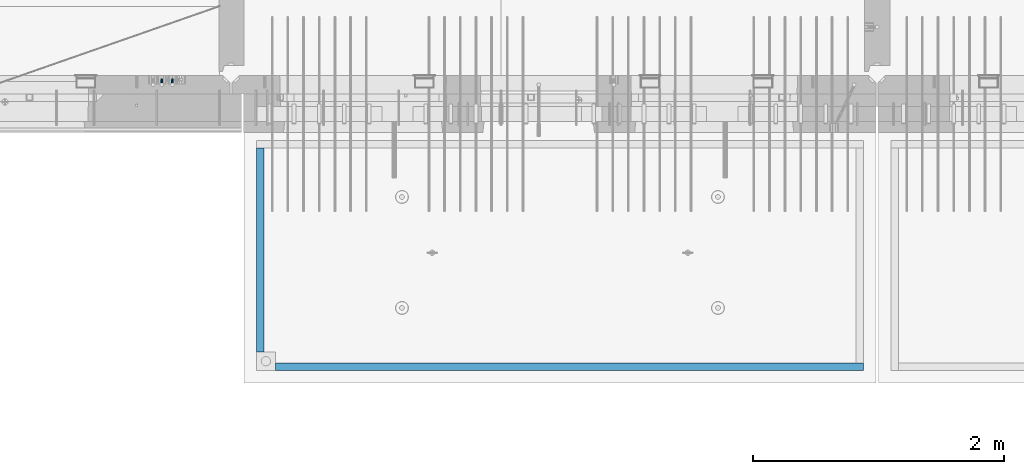
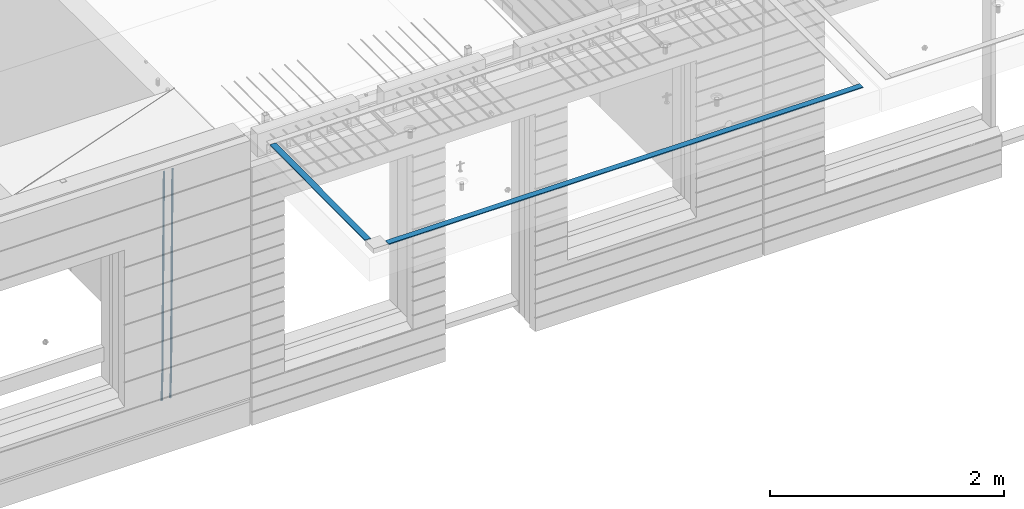
# One storey, part 95 of 350: 4 beams, 2 elements without a shape of their own.
"""IFC2X3 building model written with IfcOpenShell, lengths in millimetres."""

from ifc_helpers import new_model, si_unit, frame, origin_with_axes, place, context, subcontext, project, spatial, faceted_brep, material, type_object, element, aggregate, save


model = new_model("IFC2X3")

# Units and contexts
model_context = context("Model", 3, precision=1e-05, world=origin_with_axes())
body_context = subcontext(model_context, "Body", "Model", "MODEL_VIEW")
ifc_project = project(units=[si_unit("LENGTHUNIT", "METRE", prefix="MILLI"), si_unit("AREAUNIT", "SQUARE_METRE"), si_unit("VOLUMEUNIT", "CUBIC_METRE"), si_unit("MASSUNIT", "GRAM", prefix="KILO"), si_unit("TIMEUNIT", "SECOND"), si_unit("PLANEANGLEUNIT", "RADIAN"), si_unit("SOLIDANGLEUNIT", "STERADIAN"), si_unit("THERMODYNAMICTEMPERATUREUNIT", "DEGREE_CELSIUS"), si_unit("LUMINOUSINTENSITYUNIT", "LUMEN")], contexts=[model_context])

# Site, building, storey
site_placement = place(None, origin_with_axes())
site = spatial("IfcSite", under=ifc_project, at=site_placement, CompositionType="ELEMENT")
building_placement = place(site_placement, origin_with_axes())
building = spatial("IfcBuilding", under=site, at=building_placement, CompositionType="ELEMENT")
storey_placement = place(building_placement, origin_with_axes())
storey = spatial("IfcBuildingStorey", under=building, at=storey_placement, Name="2", CompositionType="ELEMENT", Elevation=0.0)

# Assembly, beams
assembly_1_placement = place(storey_placement, origin_with_axes())
assembly_1 = element("IfcElementAssembly", 1, at=assembly_1_placement, inside=storey, AssemblyPlace="NOTDEFINED", PredefinedType="REINFORCEMENT_UNIT")
ifc_material_1 = material()
beam_type_1 = type_object("IfcBeamType", Name="D20", PredefinedType="NOTDEFINED")
beam_1_placement = place(assembly_1_placement, frame((16189.9999999961, 7965.00000227913, 84990.0), z_axis=(0.00020576299992186, -0.999642804629538, -0.0267249099901004), x_axis=(-4.30000201928125e-08, -0.0267249099948059, 0.999642825806181)))
beam_1 = element("IfcBeam", 2, at=beam_1_placement, type_object=beam_type_1, material=ifc_material_1, Name="JM20", ObjectType="D20", context=body_context, shape_type="Brep", body=[
    faceted_brep([(0.0, -10.0, 0.0), (-4.19531716033816e-08, -7.07106781186667, -7.07106781187031), (60.4266690400545, -7.0710677960451, -7.07106780570757), (60.4266690441291, -9.99999998418934, 6.15546014159918e-09), (0.0, 0.0, -10.0), (60.426669036824, 1.58106558956206e-08, -9.99999999384454), (4.196772351861e-08, 7.07106781186303, -7.07106781186667), (60.4266690363438, 7.07106782768096, -7.07106780570757), (0.0, 10.0, 0.0), (60.4266690388904, 10.0000000158179, 6.15182216279209e-09), (4.196772351861e-08, 7.07106781185939, 7.07106781185939), (60.4266690429649, 7.07106782768096, 7.07106781802577), (0.0, 0.0, 10.0), (60.4266690461809, 1.58179318532348e-08, 10.0000000061555), (-4.19531716033816e-08, -7.07106781187031, 7.07106781185939), (60.4266690466611, -7.07106779605238, 7.07106781802213), (61.0378400410118, -7.07106779588503, -7.07106780564936), (60.991799419251, -9.99999998403655, 6.21366780251265e-09), (61.0569027789461, 1.5985278878361e-08, -9.99999999378269), (61.0378209396877, 7.07106782784831, -7.07106780564936), (60.9917724058905, 10.0000000159635, 6.21366780251265e-09), (60.9457317841297, 7.07106782781193, 7.0710678180767), (60.9266690461809, 1.59488990902901e-08, 10.0000000062028), (60.9457508854539, -7.07106779591413, 7.0710678180767), (61.6489592143771, -7.07106614513759, -7.06310863441468), (61.5568818710308, -9.9999984576425, 0.00735959856683621), (61.6870830769039, 1.71821739058942e-06, -9.99179257185824), (61.6489210170112, 7.07106947854481, -7.06310888312146), (61.556827851804, 10.0000015422847, 0.00735924683976918), (61.4647505084577, 7.07106922979438, 7.07782747982128), (61.4266266459163, 1.36643211590126e-06, 10.0065114172685), (61.464788705809, -7.07106639389531, 7.07782772852806), (176.543135720174, -7.07075579406956, -5.56673531796696), (176.451058376813, -9.99968810657447, 1.50373291501455), (176.581259582701, 0.000312069292704109, -8.49541925541052), (176.543097522794, 7.07137982961285, -5.56673556667374), (176.451004357587, 10.00031189336, 1.50373256329476), (176.35892701424, 7.07137958085514, 8.57420079627263), (176.320803151699, 0.000311717507429421, 11.5028847337162), (176.358965211621, -7.07075604281999, 8.57420104497578), (177.098753836006, -7.07075429323595, -5.55949898843028), (176.98362511232, -9.99968666800123, 1.510669025065), (177.146421932586, 0.000313595905026887, -8.48805862247536), (177.098706077581, 7.07138133041735, -5.55949936166144), (176.983557571715, 10.0003133318824, 1.51066849724157), (176.868428848029, 7.07138095712435, 8.58083651073321), (176.820760751449, 0.000313067976094317, 11.5093961447819), (176.868476606425, -7.07075466652896, 8.58083688396073), (177.654312950661, -7.07075204110879, -5.54863964998367), (177.516135294456, -9.99968450931192, 1.52107783331303), (177.711524267797, 0.000315886711177882, -8.47701274570863), (177.654255632195, 7.07138358250813, -5.54864021007961), (177.516054233929, 10.0003154905207, 1.5210770412159), (177.377876577739, 7.0713830223176, 8.59079452451624), (177.320665260588, 0.000315094497636892, 11.5191676202448), (177.377933896176, -7.07075260129932, 8.59079508461218), (299.436796249574, -7.07025836271714, -3.1681962331204), (299.298618593355, -9.99919083092027, 3.90152125031091), (299.494007566798, 0.000809565110102994, -6.09656932889993), (299.436738931283, 7.07187726089978, -3.16819679320906), (299.298537533061, 10.0008091689197, 3.90152045822106), (299.160359876842, 7.07187670072017, 10.9712379416487), (299.103148559603, 0.000808772889286047, 13.8996110374392), (299.160417195119, -7.07025892290039, 10.9712385017483), (299.98743051647, -7.07025613056248, -3.15743315966392), (299.971788958996, -9.99918809853989, 3.91467979818117), (299.993912075952, 0.000811591617093654, -6.08679785393178), (299.987423933868, 7.07187949325817, -3.1574327280432), (299.971753863239, 10.0008119014747, 3.91467990454839), (299.95611230444, 7.07187992653053, 10.9867922621015), (299.949630744944, 0.000812204350950196, 13.9161569563694), (299.956118887014, -7.07025569729012, 10.9867918304735), (300.538107039494, -7.07025785017686, -3.16575821840888), (300.644985195438, -9.99919020432935, 3.90450175465594), (300.493854948218, 0.000810030429420294, -6.09435592770024), (300.538151196495, 7.071877773491, -3.16575855385963), (300.645047642858, 10.0008097955724, 3.90450128024895), (300.751925798773, 7.07187744142357, 10.9747612533101), (300.796177890064, 0.000809560813650023, 13.9033589625978), (300.751881641787, -7.07025818224065, 10.9747615887682), (2293.36490490142, -7.07648090940347, -33.2930642912361), (2293.47178305736, -10.0054132635523, -26.2228043181785), (2293.32065281013, -0.00541302880083094, -36.2216620005347), (2293.36494905842, 7.06565471425711, -33.2930646266868), (2293.47184550477, 9.99458673634581, -26.2228047925819), (2293.57872366071, 7.06565438219332, -19.1525448195243), (2293.62297575199, -0.00541349841296324, -16.2239471102366), (2293.57867950371, -7.0764812414709, -19.1525444840736), (2294.0658245362, -7.07648309818615, -33.3036607065333), (2294.05312277409, -10.0054150789219, -26.2315929392535), (2294.10928714235, -0.00541549149056664, -36.2335844756526), (2294.15805078732, 7.06565223761572, -33.3050546393533), (2294.18355038921, 9.99458451388637, -26.2335642579346), (2294.17084862708, 7.06565253314329, -19.1614964906439), (2294.12738602093, -0.00541507354500936, -16.2315727215355), (2294.07862237596, -7.07648280265857, -19.1601025578348), (2294.76670261032, -7.08562269121467, -33.294332712383), (2294.63442802057, -10.0129954178956, -26.2238563411993), (2294.89787471293, -0.0156988342423574, -36.2230891548279), (2294.95110548967, 7.05531064255774, -33.2944998654275), (2294.89521307347, 9.98530428734011, -26.2240927312887), (2294.76293848372, 7.0579315606592, -19.1536163601049), (2294.63176638114, -0.0119922963167483, -16.2248599176673), (2294.57853560438, -7.08300177311321, -19.1534492070678), (2316.52657204497, -7.36937582653991, -33.0047303660212), (2316.39429745522, -10.2967485532172, -25.9342539948302), (2316.65774414754, -0.299451969567599, -35.9334868084661), (2316.7109749243, 6.7715575072325, -33.0048975190657), (2316.65508250811, 9.70155115201487, -25.9344903849269), (2316.52280791836, 6.7741784253376, -18.8640140137468), (2316.39163581574, -0.295745431634714, -15.9352575713092), (2316.33840503903, -7.36675490843481, -18.863846860706), (2317.16202064224, -7.37766220584308, -32.9962731735213), (2317.05438744847, -10.3053562613532, -25.9254688497131), (2317.23607125619, -0.306993473008333, -35.925789846493), (2317.23316144495, 6.76474808850253, -32.9979477328052), (2317.15499573652, 9.6950321815566, -25.9278370341635), (2317.04736254275, 6.7673381260538, -18.8570327103698), (2316.97331192881, -0.303330606784584, -15.9275160373909), (2316.97622174003, -7.37507216829545, -18.8553581510787), (2317.79752306276, -7.37578610372293, -32.9880110666527), (2317.71453320107, -10.3033876998124, -25.9168792378296), (2317.81444760226, -0.305295583297266, -35.918287695793), (2317.75539265381, 6.76628640723357, -32.9911928173897), (2317.65495180529, 9.69652304524061, -25.9213789128698), (2317.5719619436, 6.76892144914746, -18.8502470840467), (2317.55503740412, -0.301569071270933, -15.9199704549137), (2317.61409235255, -7.3731510618054, -18.847065333317), (2417.8183084176, -7.07752398473531, -31.6906369377139), (2417.73531855589, -10.0051255808248, -24.6195051088798), (2417.83523295709, -0.007033464313281, -34.6209135668432), (2417.77617800863, 7.06454852621755, -31.6938186884508), (2417.67573716014, 9.99478516423187, -24.6240047839383), (2417.59274729842, 7.06718356813872, -17.5528729551006), (2417.57582275895, -0.00330695228694822, -14.6225963259749), (2417.6348777074, -7.07488894281778, -17.5496912043673)], [[[0, 1, 2, 3]], [[1, 4, 5, 2]], [[4, 6, 7, 5]], [[6, 8, 9, 7]], [[8, 10, 11, 9]], [[10, 12, 13, 11]], [[12, 14, 15, 13]], [[14, 0, 3, 15]], [[14, 12, 10, 8, 6, 4, 1, 0]], [[3, 2, 16, 17]], [[2, 5, 18, 16]], [[5, 7, 19, 18]], [[7, 9, 20, 19]], [[9, 11, 21, 20]], [[11, 13, 22, 21]], [[13, 15, 23, 22]], [[15, 3, 17, 23]], [[17, 16, 24, 25]], [[16, 18, 26, 24]], [[18, 19, 27, 26]], [[19, 20, 28, 27]], [[20, 21, 29, 28]], [[21, 22, 30, 29]], [[22, 23, 31, 30]], [[23, 17, 25, 31]], [[25, 24, 32, 33]], [[24, 26, 34, 32]], [[26, 27, 35, 34]], [[27, 28, 36, 35]], [[28, 29, 37, 36]], [[29, 30, 38, 37]], [[30, 31, 39, 38]], [[31, 25, 33, 39]], [[33, 32, 40, 41]], [[32, 34, 42, 40]], [[34, 35, 43, 42]], [[35, 36, 44, 43]], [[36, 37, 45, 44]], [[37, 38, 46, 45]], [[38, 39, 47, 46]], [[39, 33, 41, 47]], [[41, 40, 48, 49]], [[40, 42, 50, 48]], [[42, 43, 51, 50]], [[43, 44, 52, 51]], [[44, 45, 53, 52]], [[45, 46, 54, 53]], [[46, 47, 55, 54]], [[47, 41, 49, 55]], [[49, 48, 56, 57]], [[48, 50, 58, 56]], [[50, 51, 59, 58]], [[51, 52, 60, 59]], [[52, 53, 61, 60]], [[53, 54, 62, 61]], [[54, 55, 63, 62]], [[55, 49, 57, 63]], [[57, 56, 64, 65]], [[56, 58, 66, 64]], [[58, 59, 67, 66]], [[59, 60, 68, 67]], [[60, 61, 69, 68]], [[61, 62, 70, 69]], [[62, 63, 71, 70]], [[63, 57, 65, 71]], [[65, 64, 72, 73]], [[64, 66, 74, 72]], [[66, 67, 75, 74]], [[67, 68, 76, 75]], [[68, 69, 77, 76]], [[69, 70, 78, 77]], [[70, 71, 79, 78]], [[71, 65, 73, 79]], [[73, 72, 80, 81]], [[72, 74, 82, 80]], [[74, 75, 83, 82]], [[75, 76, 84, 83]], [[76, 77, 85, 84]], [[77, 78, 86, 85]], [[78, 79, 87, 86]], [[79, 73, 81, 87]], [[81, 80, 88, 89]], [[80, 82, 90, 88]], [[82, 83, 91, 90]], [[83, 84, 92, 91]], [[84, 85, 93, 92]], [[85, 86, 94, 93]], [[86, 87, 95, 94]], [[87, 81, 89, 95]], [[89, 88, 96, 97]], [[88, 90, 98, 96]], [[90, 91, 99, 98]], [[91, 92, 100, 99]], [[92, 93, 101, 100]], [[93, 94, 102, 101]], [[94, 95, 103, 102]], [[95, 89, 97, 103]], [[97, 96, 104, 105]], [[96, 98, 106, 104]], [[98, 99, 107, 106]], [[99, 100, 108, 107]], [[100, 101, 109, 108]], [[101, 102, 110, 109]], [[102, 103, 111, 110]], [[103, 97, 105, 111]], [[105, 104, 112, 113]], [[104, 106, 114, 112]], [[106, 107, 115, 114]], [[107, 108, 116, 115]], [[108, 109, 117, 116]], [[109, 110, 118, 117]], [[110, 111, 119, 118]], [[111, 105, 113, 119]], [[113, 112, 120, 121]], [[112, 114, 122, 120]], [[114, 115, 123, 122]], [[115, 116, 124, 123]], [[116, 117, 125, 124]], [[117, 118, 126, 125]], [[118, 119, 127, 126]], [[119, 113, 121, 127]], [[121, 120, 128, 129]], [[120, 122, 130, 128]], [[122, 123, 131, 130]], [[123, 124, 132, 131]], [[124, 125, 133, 132]], [[125, 126, 134, 133]], [[126, 127, 135, 134]], [[127, 121, 129, 135]], [[130, 131, 132, 133, 134, 135, 129, 128]]]),
])
beam_2_placement = place(assembly_1_placement, frame((16104.9999999961, 7965.00000227913, 84990.0), z_axis=(0.00020576299992186, -0.999642804629538, -0.0267249099901004), x_axis=(-4.30000201928125e-08, -0.0267249099948059, 0.999642825806181)))
beam_2 = element("IfcBeam", 3, at=beam_2_placement, type_object=beam_type_1, material=ifc_material_1, Name="JM20", ObjectType="D20", context=body_context, shape_type="Brep", body=[
    faceted_brep([(0.0, -10.0, 0.0), (-4.19531716033816e-08, -7.07106781186667, -7.07106781187031), (60.4266690400545, -7.0710677960451, -7.07106780570757), (60.4266690441291, -9.99999998418934, 6.15546014159918e-09), (0.0, 0.0, -10.0), (60.426669036824, 1.58106558956206e-08, -9.99999999384454), (4.196772351861e-08, 7.07106781186303, -7.07106781186667), (60.4266690363438, 7.07106782768096, -7.07106780570757), (0.0, 10.0, 0.0), (60.4266690388904, 10.0000000158179, 6.15182216279209e-09), (4.196772351861e-08, 7.07106781185939, 7.07106781185939), (60.4266690429649, 7.07106782768096, 7.07106781802577), (0.0, 0.0, 10.0), (60.4266690461809, 1.58179318532348e-08, 10.0000000061555), (-4.19531716033816e-08, -7.07106781187031, 7.07106781185939), (60.4266690466611, -7.07106779605238, 7.07106781802213), (61.0378400410118, -7.07106779588503, -7.07106780564936), (60.991799419251, -9.99999998403655, 6.21366780251265e-09), (61.0569027789461, 1.5985278878361e-08, -9.99999999378269), (61.0378209396877, 7.07106782784831, -7.07106780564936), (60.9917724058905, 10.0000000159635, 6.21366780251265e-09), (60.9457317841297, 7.07106782781193, 7.0710678180767), (60.9266690461809, 1.59488990902901e-08, 10.0000000062028), (60.9457508854539, -7.07106779591413, 7.0710678180767), (61.6489592143771, -7.07106614513759, -7.06310863441468), (61.5568818710308, -9.9999984576425, 0.00735959856683621), (61.6870830769039, 1.71821739058942e-06, -9.99179257185824), (61.6489210170112, 7.07106947854481, -7.06310888312146), (61.556827851804, 10.0000015422847, 0.00735924683976918), (61.4647505084577, 7.07106922979438, 7.07782747982128), (61.4266266459163, 1.36643211590126e-06, 10.0065114172685), (61.464788705809, -7.07106639389531, 7.07782772852806), (176.543135720174, -7.07075579406956, -5.56673531796696), (176.451058376813, -9.99968810657447, 1.50373291501455), (176.581259582701, 0.000312069292704109, -8.49541925541052), (176.543097522794, 7.07137982961285, -5.56673556667374), (176.451004357587, 10.00031189336, 1.50373256329476), (176.35892701424, 7.07137958085514, 8.57420079627263), (176.320803151699, 0.000311717507429421, 11.5028847337162), (176.358965211621, -7.07075604281999, 8.57420104497578), (177.098753836006, -7.07075429323595, -5.55949898843028), (176.98362511232, -9.99968666800123, 1.510669025065), (177.146421932586, 0.000313595905026887, -8.48805862247536), (177.098706077581, 7.07138133041735, -5.55949936166144), (176.983557571715, 10.0003133318824, 1.51066849724157), (176.868428848029, 7.07138095712435, 8.58083651073321), (176.820760751449, 0.000313067976094317, 11.5093961447819), (176.868476606425, -7.07075466652896, 8.58083688396073), (177.654312950661, -7.07075204110879, -5.54863964998367), (177.516135294456, -9.99968450931192, 1.52107783331303), (177.711524267797, 0.000315886711177882, -8.47701274570863), (177.654255632195, 7.07138358250813, -5.54864021007961), (177.516054233929, 10.0003154905207, 1.5210770412159), (177.377876577739, 7.0713830223176, 8.59079452451624), (177.320665260588, 0.000315094497636892, 11.5191676202448), (177.377933896176, -7.07075260129932, 8.59079508461218), (299.436796249574, -7.07025836271714, -3.1681962331204), (299.298618593355, -9.99919083092027, 3.90152125031091), (299.494007566798, 0.000809565110102994, -6.09656932889993), (299.436738931283, 7.07187726089978, -3.16819679320906), (299.298537533061, 10.0008091689197, 3.90152045822106), (299.160359876842, 7.07187670072017, 10.9712379416487), (299.103148559603, 0.000808772889286047, 13.8996110374392), (299.160417195119, -7.07025892290039, 10.9712385017483), (299.98743051647, -7.07025613056248, -3.15743315966392), (299.971788958996, -9.99918809853989, 3.91467979818117), (299.993912075952, 0.000811591617093654, -6.08679785393178), (299.987423933868, 7.07187949325817, -3.1574327280432), (299.971753863239, 10.0008119014747, 3.91467990454839), (299.95611230444, 7.07187992653053, 10.9867922621015), (299.949630744944, 0.000812204350950196, 13.9161569563694), (299.956118887014, -7.07025569729012, 10.9867918304735), (300.538107039494, -7.07025785017686, -3.16575821840888), (300.644985195438, -9.99919020432935, 3.90450175465594), (300.493854948218, 0.000810030429420294, -6.09435592770024), (300.538151196495, 7.071877773491, -3.16575855385963), (300.645047642858, 10.0008097955724, 3.90450128024895), (300.751925798773, 7.07187744142357, 10.9747612533101), (300.796177890064, 0.000809560813650023, 13.9033589625978), (300.751881641787, -7.07025818224065, 10.9747615887682), (2293.36490490142, -7.07648090940347, -33.2930642912361), (2293.47178305736, -10.0054132635523, -26.2228043181785), (2293.32065281013, -0.00541302880083094, -36.2216620005347), (2293.36494905842, 7.06565471425711, -33.2930646266868), (2293.47184550477, 9.99458673634581, -26.2228047925819), (2293.57872366071, 7.06565438219332, -19.1525448195243), (2293.62297575199, -0.00541349841296324, -16.2239471102366), (2293.57867950371, -7.0764812414709, -19.1525444840736), (2294.0658245362, -7.07648309818615, -33.3036607065333), (2294.05312277409, -10.0054150789219, -26.2315929392535), (2294.10928714235, -0.00541549149056664, -36.2335844756526), (2294.15805078732, 7.06565223761572, -33.3050546393533), (2294.18355038921, 9.99458451388637, -26.2335642579346), (2294.17084862708, 7.06565253314329, -19.1614964906439), (2294.12738602093, -0.00541507354500936, -16.2315727215355), (2294.07862237596, -7.07648280265857, -19.1601025578348), (2294.76670261032, -7.08562269121467, -33.294332712383), (2294.63442802057, -10.0129954178956, -26.2238563411993), (2294.89787471293, -0.0156988342423574, -36.2230891548279), (2294.95110548967, 7.05531064255774, -33.2944998654275), (2294.89521307347, 9.98530428734011, -26.2240927312887), (2294.76293848372, 7.0579315606592, -19.1536163601049), (2294.63176638114, -0.0119922963167483, -16.2248599176673), (2294.57853560438, -7.08300177311321, -19.1534492070678), (2316.52657204497, -7.36937582653991, -33.0047303660212), (2316.39429745522, -10.2967485532172, -25.9342539948302), (2316.65774414754, -0.299451969567599, -35.9334868084661), (2316.7109749243, 6.7715575072325, -33.0048975190657), (2316.65508250811, 9.70155115201487, -25.9344903849269), (2316.52280791836, 6.7741784253376, -18.8640140137468), (2316.39163581574, -0.295745431634714, -15.9352575713092), (2316.33840503903, -7.36675490843481, -18.863846860706), (2317.16202064224, -7.37766220584308, -32.9962731735213), (2317.05438744847, -10.3053562613532, -25.9254688497131), (2317.23607125619, -0.306993473008333, -35.925789846493), (2317.23316144495, 6.76474808850253, -32.9979477328052), (2317.15499573652, 9.6950321815566, -25.9278370341635), (2317.04736254275, 6.7673381260538, -18.8570327103698), (2316.97331192881, -0.303330606784584, -15.9275160373909), (2316.97622174003, -7.37507216829545, -18.8553581510787), (2317.79752306276, -7.37578610372293, -32.9880110666527), (2317.71453320107, -10.3033876998124, -25.9168792378296), (2317.81444760226, -0.305295583297266, -35.918287695793), (2317.75539265381, 6.76628640723357, -32.9911928173897), (2317.65495180529, 9.69652304524061, -25.9213789128698), (2317.5719619436, 6.76892144914746, -18.8502470840467), (2317.55503740412, -0.301569071270933, -15.9199704549137), (2317.61409235255, -7.3731510618054, -18.847065333317), (2417.8183084176, -7.07752398473531, -31.6906369377139), (2417.73531855589, -10.0051255808248, -24.6195051088798), (2417.83523295709, -0.007033464313281, -34.6209135668432), (2417.77617800863, 7.06454852621755, -31.6938186884508), (2417.67573716014, 9.99478516423187, -24.6240047839383), (2417.59274729842, 7.06718356813872, -17.5528729551006), (2417.57582275895, -0.00330695228694822, -14.6225963259749), (2417.6348777074, -7.07488894281778, -17.5496912043673)], [[[0, 1, 2, 3]], [[1, 4, 5, 2]], [[4, 6, 7, 5]], [[6, 8, 9, 7]], [[8, 10, 11, 9]], [[10, 12, 13, 11]], [[12, 14, 15, 13]], [[14, 0, 3, 15]], [[14, 12, 10, 8, 6, 4, 1, 0]], [[3, 2, 16, 17]], [[2, 5, 18, 16]], [[5, 7, 19, 18]], [[7, 9, 20, 19]], [[9, 11, 21, 20]], [[11, 13, 22, 21]], [[13, 15, 23, 22]], [[15, 3, 17, 23]], [[17, 16, 24, 25]], [[16, 18, 26, 24]], [[18, 19, 27, 26]], [[19, 20, 28, 27]], [[20, 21, 29, 28]], [[21, 22, 30, 29]], [[22, 23, 31, 30]], [[23, 17, 25, 31]], [[25, 24, 32, 33]], [[24, 26, 34, 32]], [[26, 27, 35, 34]], [[27, 28, 36, 35]], [[28, 29, 37, 36]], [[29, 30, 38, 37]], [[30, 31, 39, 38]], [[31, 25, 33, 39]], [[33, 32, 40, 41]], [[32, 34, 42, 40]], [[34, 35, 43, 42]], [[35, 36, 44, 43]], [[36, 37, 45, 44]], [[37, 38, 46, 45]], [[38, 39, 47, 46]], [[39, 33, 41, 47]], [[41, 40, 48, 49]], [[40, 42, 50, 48]], [[42, 43, 51, 50]], [[43, 44, 52, 51]], [[44, 45, 53, 52]], [[45, 46, 54, 53]], [[46, 47, 55, 54]], [[47, 41, 49, 55]], [[49, 48, 56, 57]], [[48, 50, 58, 56]], [[50, 51, 59, 58]], [[51, 52, 60, 59]], [[52, 53, 61, 60]], [[53, 54, 62, 61]], [[54, 55, 63, 62]], [[55, 49, 57, 63]], [[57, 56, 64, 65]], [[56, 58, 66, 64]], [[58, 59, 67, 66]], [[59, 60, 68, 67]], [[60, 61, 69, 68]], [[61, 62, 70, 69]], [[62, 63, 71, 70]], [[63, 57, 65, 71]], [[65, 64, 72, 73]], [[64, 66, 74, 72]], [[66, 67, 75, 74]], [[67, 68, 76, 75]], [[68, 69, 77, 76]], [[69, 70, 78, 77]], [[70, 71, 79, 78]], [[71, 65, 73, 79]], [[73, 72, 80, 81]], [[72, 74, 82, 80]], [[74, 75, 83, 82]], [[75, 76, 84, 83]], [[76, 77, 85, 84]], [[77, 78, 86, 85]], [[78, 79, 87, 86]], [[79, 73, 81, 87]], [[81, 80, 88, 89]], [[80, 82, 90, 88]], [[82, 83, 91, 90]], [[83, 84, 92, 91]], [[84, 85, 93, 92]], [[85, 86, 94, 93]], [[86, 87, 95, 94]], [[87, 81, 89, 95]], [[89, 88, 96, 97]], [[88, 90, 98, 96]], [[90, 91, 99, 98]], [[91, 92, 100, 99]], [[92, 93, 101, 100]], [[93, 94, 102, 101]], [[94, 95, 103, 102]], [[95, 89, 97, 103]], [[97, 96, 104, 105]], [[96, 98, 106, 104]], [[98, 99, 107, 106]], [[99, 100, 108, 107]], [[100, 101, 109, 108]], [[101, 102, 110, 109]], [[102, 103, 111, 110]], [[103, 97, 105, 111]], [[105, 104, 112, 113]], [[104, 106, 114, 112]], [[106, 107, 115, 114]], [[107, 108, 116, 115]], [[108, 109, 117, 116]], [[109, 110, 118, 117]], [[110, 111, 119, 118]], [[111, 105, 113, 119]], [[113, 112, 120, 121]], [[112, 114, 122, 120]], [[114, 115, 123, 122]], [[115, 116, 124, 123]], [[116, 117, 125, 124]], [[117, 118, 126, 125]], [[118, 119, 127, 126]], [[119, 113, 121, 127]], [[121, 120, 128, 129]], [[120, 122, 130, 128]], [[122, 123, 131, 130]], [[123, 124, 132, 131]], [[124, 125, 133, 132]], [[125, 126, 134, 133]], [[126, 127, 135, 134]], [[127, 121, 129, 135]], [[130, 131, 132, 133, 134, 135, 129, 128]]]),
])
aggregate(assembly_1, [beam_1, beam_2])

assembly_2_placement = place(storey_placement, origin_with_axes())
assembly_2 = element("IfcElementAssembly", 4, at=assembly_2_placement, inside=storey, AssemblyPlace="NOTDEFINED", PredefinedType="REINFORCEMENT_UNIT")
ifc_material_2 = material(Name="CONCRETE/Concrete_Undefined")
beam_type_2 = type_object("IfcBeamType", PredefinedType="NOTDEFINED")
beam_3_placement = place(assembly_2_placement, frame((17009.999743725, 5674.95858499901, 87709.8102146119), z_axis=(0.000380798000187366, 3.00000010760189e-09, 0.999999927496439), x_axis=(0.99999992747398, 6.70200000315108e-06, -0.000380798000181631)))
beam_3 = element("IfcBeam", 5, at=beam_3_placement, type_object=beam_type_2, material=ifc_material_2, context=body_context, shape_type="Brep", body=[
    faceted_brep([(2.5465851649642e-11, 29.9999999999982, -4.99999999998545), (-2.91038304567337e-11, 29.9999999999982, 5.0), (4690.00295566467, 30.0, 5.00000000001455), (4690.00295566467, 30.0000000000009, -4.99999999998545), (-2.5465851649642e-11, -30.0000000000018, 5.0), (4690.00295566467, -30.0, 5.00000000001455), (2.72848410531878e-11, -30.0000000000018, -4.99999999998545), (4690.00295566467, -30.0, -5.0)], [[[0, 1, 2, 3]], [[1, 4, 5, 2]], [[4, 6, 7, 5]], [[6, 0, 3, 7]], [[5, 7, 3, 2]], [[6, 4, 1, 0]]]),
])
beam_4_placement = place(assembly_2_placement, frame((16889.9913896902, 7420.06323332097, 87723.6636421195), z_axis=(3.06000001756964e-07, -0.00861454800079991, 0.9999628940929), x_axis=(3.55420000171828e-05, -0.999962893461279, -0.00861454800397781)))
beam_4 = element("IfcBeam", 6, at=beam_4_placement, type_object=beam_type_2, material=ifc_material_2, context=body_context, shape_type="Brep", body=[
    faceted_brep([(2.5465851649642e-11, 29.9999999999982, -4.99999999998545), (-2.91038304567337e-11, 29.9999999999982, 5.0), (1625.15608040099, 30.0000000000073, 5.0), (1625.15608040101, 30.0000000000036, -4.99999999998545), (-2.5465851649642e-11, -30.0000000000018, 5.0), (1625.15608040099, -29.9999999999964, 5.0), (2.72848410531878e-11, -30.0000000000018, -4.99999999998545), (1625.15608040101, -29.9999999999964, -4.99999999998545)], [[[0, 1, 2, 3]], [[1, 4, 5, 2]], [[4, 6, 7, 5]], [[6, 0, 3, 7]], [[5, 7, 3, 2]], [[6, 4, 1, 0]]]),
])
aggregate(assembly_2, [beam_3, beam_4])

save(model, "model.ifc")
